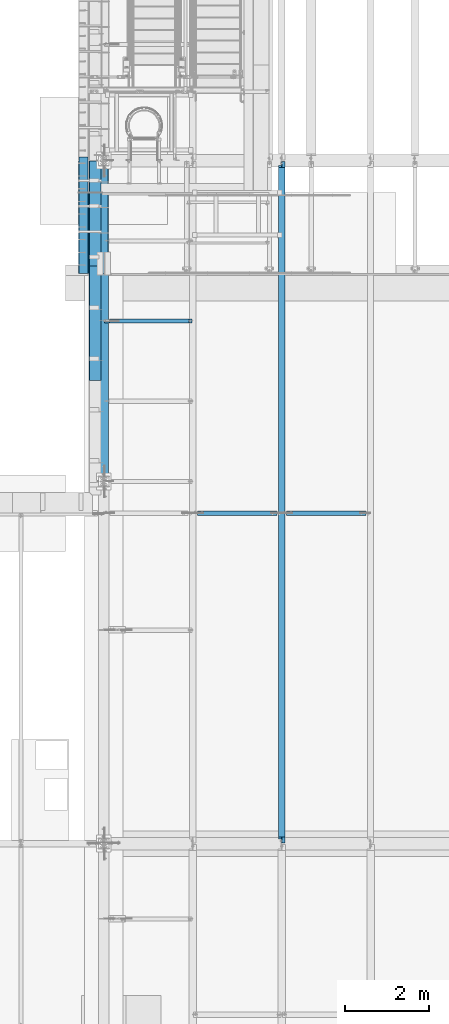
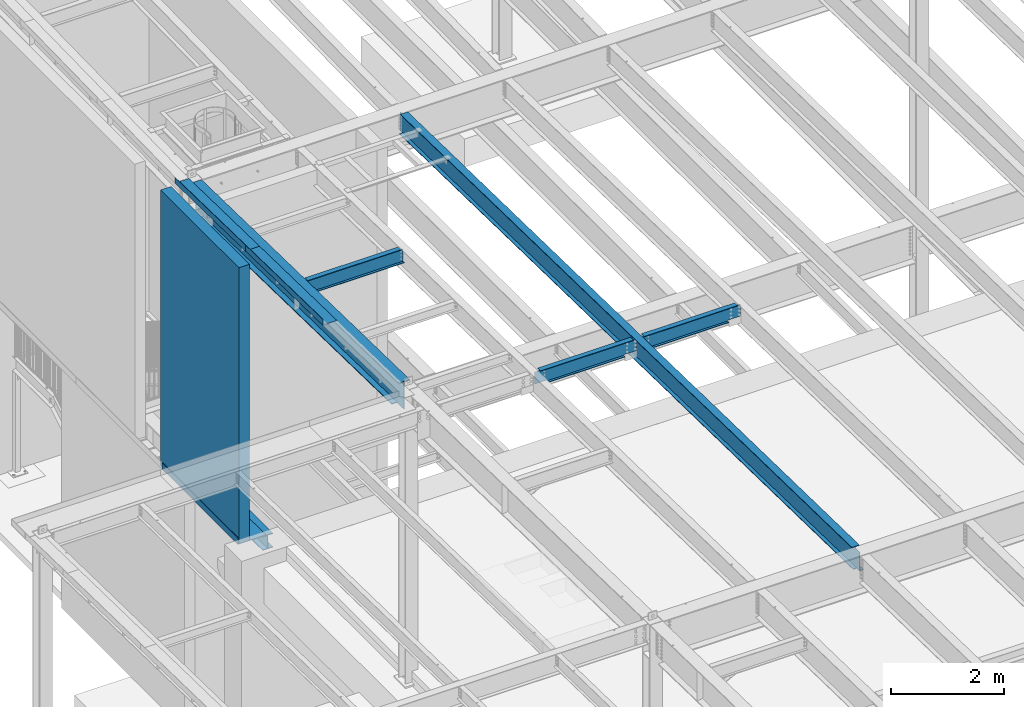
# One storey, part 1072 of 1763: 10 beams, 7 elements without a shape of their own.
"""IFC2X3 building model written with IfcOpenShell, lengths in millimetres."""

from ifc_helpers import new_model, si_unit, frame, origin_with_axes, place, context, subcontext, project, spatial, faceted_brep, material, type_object, element, aggregate, save


model = new_model("IFC2X3")

# Units and contexts
model_context = context("Model", 3, precision=1e-05, world=origin_with_axes())
body_context = subcontext(model_context, "Body", "Model", "MODEL_VIEW")
ifc_project = project(units=[si_unit("LENGTHUNIT", "METRE", prefix="MILLI"), si_unit("AREAUNIT", "SQUARE_METRE"), si_unit("VOLUMEUNIT", "CUBIC_METRE"), si_unit("MASSUNIT", "GRAM", prefix="KILO"), si_unit("TIMEUNIT", "SECOND"), si_unit("PLANEANGLEUNIT", "RADIAN"), si_unit("SOLIDANGLEUNIT", "STERADIAN"), si_unit("THERMODYNAMICTEMPERATUREUNIT", "DEGREE_CELSIUS"), si_unit("LUMINOUSINTENSITYUNIT", "LUMEN")], contexts=[model_context])

# Site, building, storey
site_placement = place(None, origin_with_axes())
site = spatial("IfcSite", under=ifc_project, at=site_placement, CompositionType="ELEMENT")
building_placement = place(site_placement, origin_with_axes())
building = spatial("IfcBuilding", under=site, at=building_placement, Name="Undefined", CompositionType="ELEMENT")
storey_placement = place(building_placement, origin_with_axes())
storey = spatial("IfcBuildingStorey", under=building, at=storey_placement, Name="Undefined", CompositionType="ELEMENT", Elevation=0.0)

# Assembly, beam
assembly_1_placement = place(storey_placement, origin_with_axes())
assembly_1 = element("IfcElementAssembly", 1, at=assembly_1_placement, inside=storey, Name="WALL", AssemblyPlace="NOTDEFINED", PredefinedType="REINFORCEMENT_UNIT")
ifc_material_1 = material(Name="CONCRETE/5000")
beam_type_1 = type_object("IfcBeamType", PredefinedType="NOTDEFINED")
beam_1_placement = place(assembly_1_placement, frame((-87858.0372736983, 27330.4000061035, 8189.9125), z_axis=(-1.0, 0.0, 0.0), x_axis=(0.0, 1.0, 0.0)))
beam_1 = element("IfcBeam", 2, at=beam_1_placement, type_object=beam_type_1, material=ifc_material_1, Name="WALL", context=body_context, shape_type="Brep", body=[
    faceted_brep([(0.0, 2986.0875, -107.949999999997), (0.0, 2986.0875, 107.949999999997), (2778.1249938965, 2986.0875, 107.949999999997), (2778.1249938965, 2986.0875, -107.949999999997), (0.0, -2986.0875, 107.949999999997), (2778.1249938965, -2986.0875, 107.949999999997), (0.0, -2986.0875, -107.949999999997), (2778.1249938965, -2986.0875, -107.949999999997)], [[[0, 1, 2, 3]], [[1, 4, 5, 2]], [[4, 6, 7, 5]], [[6, 0, 3, 7]], [[5, 7, 3, 2]], [[6, 4, 1, 0]]]),
])
aggregate(assembly_1, [beam_1])

assembly_2_placement = place(storey_placement, origin_with_axes())
assembly_2 = element("IfcElementAssembly", 3, at=assembly_2_placement, inside=storey, Name="BEAM", AssemblyPlace="NOTDEFINED", PredefinedType="RIGID_FRAME")
ifc_material_2 = material(Name="STEEL/A36")
beam_type_2 = type_object("IfcBeamType", PredefinedType="NOTDEFINED")
beam_2_placement = place(assembly_2_placement, frame((-87413.5372736984, 28675.0125, 5199.0625), z_axis=(0.0, -1.0, 0.0), x_axis=(-1.0, 0.0, 0.0)))
beam_2 = element("IfcBeam", 4, at=beam_2_placement, type_object=beam_type_2, material=ifc_material_2, Name="BENT_PLATE", context=body_context, shape_type="Brep", body=[
    faceted_brep([(349.250003051988, -4.76249999999982, -776.287548828121), (349.250003051988, 4.76249999999982, -776.287548828121), (349.250000000233, 4.76249999999982, -1344.6125), (349.250000000233, -4.76249999999982, -1344.6125), (0.0, -4.76249999999982, -776.287548828121), (0.0, 4.76249999999982, -776.287548828121), (571.5, 4.76249999999982, 1344.6125), (0.0, 4.76249999999982, 1344.6125), (0.0, -4.76249999999982, 1344.6125), (561.975000000006, -4.76249999999982, 1344.6125), (561.975000000006, -134.937496948242, 1344.6125), (571.5, -134.937496948242, 1344.6125), (571.5, 4.76249999999982, -1344.6125), (571.5, -134.937496948242, -1344.6125), (561.975000000006, -134.937496948242, -1344.6125), (561.975000000006, -4.76249999999982, -1344.6125)], [[[0, 1, 2, 3]], [[4, 5, 1, 0]], [[6, 7, 8, 9, 10, 11]], [[12, 6, 11, 13]], [[10, 14, 13, 11]], [[9, 15, 14, 10]], [[12, 13, 14, 15, 3, 2]], [[7, 6, 12, 2, 1, 5]], [[8, 7, 5, 4]], [[15, 9, 8, 4, 0, 3]]]),
])

# Assembly, beams
assembly_3_placement = place(storey_placement, origin_with_axes())
assembly_3 = element("IfcElementAssembly", 5, at=assembly_3_placement, inside=storey, Name="BEAM", AssemblyPlace="NOTDEFINED", PredefinedType="RIGID_FRAME")
beam_type_3 = type_object("IfcBeamType", PredefinedType="NOTDEFINED")
beam_3_placement = place(assembly_3_placement, frame((-87438.9372736983, 28764.1962141593, 11319.7790149965), z_axis=(0.0, -0.999781691287208, 0.0208942520059919), x_axis=(-1.0, 0.0, 0.0)))
beam_3 = element("IfcBeam", 6, at=beam_3_placement, type_object=beam_type_3, material=ifc_material_2, Name="BENT_PLATE", context=body_context, shape_type="Brep", body=[
    faceted_brep([(-5.0931703299284e-10, -3.17500000032851, -1254.12450000018), (7.13043846189976e-10, -3.17499999967549, 1254.12450000017), (5.0931703299284e-10, 3.17500000032305, 1254.12450000018), (-7.13043846189976e-10, 3.17499999967367, -1254.12450000018), (285.74999999514, 3.17500000944892, 1254.12450000004), (285.749999991167, 3.17500000879954, -1254.12450000031), (279.399999991176, -3.17499999140637, -1254.12450000032), (279.399999995148, -3.17499999075517, 1254.12450000003), (285.749999993728, -123.824999977416, 1254.1244999997), (285.749999992593, -123.824999975288, -1254.12450000065), (279.399999993722, -123.824999977416, 1254.12449999971), (279.399999992587, -123.824999975288, -1254.12450000064)], [[[0, 1, 2, 3]], [[3, 2, 4, 5]], [[1, 0, 6, 7]], [[5, 4, 8, 9]], [[4, 2, 1, 7, 10, 8]], [[7, 6, 11, 10]], [[6, 0, 3, 5, 9, 11]], [[10, 11, 9, 8]]]),
])
beam_4_placement = place(assembly_3_placement, frame((-87438.9372736983, 26139.0449326945, 11374.6415643874), z_axis=(0.0, -0.999781691287208, 0.0208942520059919), x_axis=(-1.0, 0.0, 0.0)))
beam_4 = element("IfcBeam", 7, at=beam_4_placement, type_object=beam_type_3, material=ifc_material_2, Name="BENT_PLATE", context=body_context, shape_type="Brep", body=[
    faceted_brep([(2.91038304567337e-11, -3.17499999963729, -1371.60000000396), (-2.91038304567337e-11, -3.17500000036489, 1371.60000000395), (-2.91038304567337e-11, 3.17499999963184, 1371.60000000395), (2.91038304567337e-11, 3.17500000035943, -1371.60000000396), (285.75000000016, 3.17499999930078, 1371.59999999897), (285.750000000276, 3.17499999982283, -1371.59999999897), (279.400000000271, -3.1750000001648, -1371.59999999897), (279.400000000154, -3.17500000068321, 1371.59999999897), (285.750000000218, -123.824997298658, 1371.59999999895), (285.750000000218, -123.824997298212, -1371.59999999898), (279.400000000212, -123.824997298658, 1371.59999999895), (279.400000000212, -123.824997298212, -1371.59999999898)], [[[0, 1, 2, 3]], [[3, 2, 4, 5]], [[1, 0, 6, 7]], [[5, 4, 8, 9]], [[4, 2, 1, 7, 10, 8]], [[7, 6, 11, 10]], [[6, 0, 3, 5, 9, 11]], [[10, 11, 9, 8]]]),
])

# Assembly, beam
assembly_4_placement = place(storey_placement, origin_with_axes())
assembly_4 = element("IfcElementAssembly", 8, at=assembly_4_placement, inside=storey, Name="BEAM", AssemblyPlace="NOTDEFINED", PredefinedType="RIGID_FRAME")
ifc_material_3 = material(Name="STEEL/A992")
beam_type_4 = type_object("IfcBeamType", Name="W18X40", PredefinedType="NOTDEFINED")
beam_5_placement = place(assembly_4_placement, frame((-83122.7515594126, 13685.8551306872, 11404.7768219843), z_axis=(0.0, 0.0209013539966291, 0.999781542838788), x_axis=(0.0, 0.999781542776098, -0.0209013569953182)))
beam_5 = element("IfcBeam", 9, at=beam_5_placement, type_object=beam_type_4, material=ifc_material_3, Name="BEAM", ObjectType="W18X40", context=body_context, shape_type="Brep", body=[
    faceted_brep([(126.194002738479, 4.26866853985121, -214.312499999893), (126.194002738466, 4.2688283926982, -227.01249999989), (29.339897632873, 4.26882972748717, -227.01250000019), (29.0743924101943, 4.26863241521642, -214.31250000018), (126.193992739341, 76.1999999999971, -214.312499999894), (126.193992739347, 76.1999999999971, -227.01249999989), (164.293992016979, -3.96875, 195.002501487832), (164.293992016979, 3.96875, 195.002501487832), (163.327262094397, 3.96875, 190.142421969791), (163.327262094397, -3.96875, 190.142421969791), (160.574248193921, 3.96875, 186.022245501637), (160.574248193921, -3.96875, 186.022245501637), (156.454071725771, 3.96875, 183.269231601158), (156.454071725771, -3.96875, 183.269231601158), (151.593992207727, 3.96875, 182.302501678567), (151.593992207727, -3.96875, 182.302501678567), (20.7827897637508, 3.96875, 182.30250167849), (20.7827897637508, -3.96875, 182.30250167849), (29.0743924101943, -3.96875, -214.31250000018), (16325.1468877506, -3.96875, -214.312499990354), (16317.1207899894, -3.96875, 169.60249800784), (16187.3164864569, -3.96875, 169.602498007764), (16182.4564069388, -3.96875, 170.569227930349), (16178.3362304707, -3.96875, 173.322241830821), (16175.5832165702, -3.96875, 177.442418298971), (16174.6164866476, -3.96875, 182.302497817014), (16174.6164868948, -3.96875, 214.312500009495), (164.29399201697, -3.96875, 214.312500000067), (29.0743924101943, -76.1999999999971, -214.31250000018), (16325.1468877506, -76.1999999999971, -214.312499990354), (29.339897632873, -76.1999999999971, -227.01250000019), (16325.412392986, -76.1999999999971, -227.012499990351), (16225.1450550741, 76.1999999999971, -215.844156205017), (16225.1450550741, 4.71875000001455, -215.844156205017), (16225.4164836211, 4.71875000001455, -215.838481740431), (16225.4164771875, 76.1999999999971, -215.838481874931), (16225.1130343856, 4.71875000001455, -214.312499990412), (16225.1130343856, 76.1999999999971, -214.312499990412), (16225.4164836211, 4.71875000001455, -214.312499990414), (16225.4164838328, 4.26882845565706, -214.312499990412), (16225.4164838328, 4.26866860519658, -227.012499990411), (16225.4164773588, 76.1999999999971, -227.012499990409), (16325.412392986, 4.2686776052069, -227.012499990351), (16325.1468877506, 4.26883743175858, -214.312499990354), (16325.1468877506, 3.96875, -214.312499990354), (16317.1207899894, 3.96875, 169.60249800784), (16187.3164864569, 3.96875, 169.602498007764), (16182.4564069388, 3.96875, 170.569227930349), (16178.3362304707, 3.96875, 173.322241830821), (16175.5832165702, 3.96875, 177.442418298971), (16174.6164866476, 3.96875, 182.302497817014), (16174.6164868948, -76.1999999999971, 227.01250000949), (16174.6164868948, -76.1999999999971, 214.312500009495), (16174.6164868948, 3.96875, 214.312500009495), (16174.6164868948, 76.1999999999971, 214.312500009495), (16174.6164868948, 76.1999999999971, 227.01250000949), (164.29399201697, 3.96875, 214.312500000067), (164.29399201697, 76.1999999999971, 214.312500000067), (164.293992016963, 76.1999999999971, 227.012500000064), (164.293992016963, -76.1999999999971, 227.012500000064), (164.29399201697, -76.1999999999971, 214.312500000067), (29.0743924101943, 3.96875, -214.31250000018)], [[[0, 1, 2, 3]], [[4, 5, 1, 0]], [[6, 7, 8, 9]], [[9, 8, 10, 11]], [[11, 10, 12, 13]], [[13, 12, 14, 15]], [[15, 14, 16, 17]], [[9, 11, 13, 15, 17, 18, 19, 20, 21, 22, 23, 24, 25, 26, 27, 6]], [[18, 28, 29, 19]], [[28, 30, 31, 29]], [[32, 33, 34, 35]], [[36, 33, 32, 37]], [[33, 36, 38, 34]], [[39, 40, 41, 35, 34, 38]], [[42, 40, 39, 43]], [[44, 45, 20, 19, 29, 31, 42, 43]], [[20, 45, 46, 21]], [[21, 46, 47, 22]], [[22, 47, 48, 23]], [[23, 48, 49, 24]], [[24, 49, 50, 25]], [[51, 52, 26, 25, 50, 53, 54, 55]], [[54, 53, 56, 57]], [[55, 54, 57, 58]], [[51, 55, 58, 59]], [[52, 51, 59, 60]], [[26, 52, 60, 27]], [[59, 58, 57, 56, 7, 6, 27, 60]], [[53, 50, 49, 48, 47, 46, 45, 44, 61, 16, 14, 12, 10, 8, 7, 56]], [[30, 28, 18, 17, 16, 61, 3, 2]], [[41, 40, 42, 31, 30, 2, 1, 5]], [[37, 32, 35, 41, 5, 4]], [[61, 44, 43, 39, 38, 36, 37, 4, 0, 3]]]),
])
aggregate(assembly_4, [beam_5])

assembly_5_placement = place(storey_placement, origin_with_axes())
assembly_5 = element("IfcElementAssembly", 10, at=assembly_5_placement, inside=storey, Name="BEAM", AssemblyPlace="NOTDEFINED", PredefinedType="RIGID_FRAME")
beam_type_5 = type_object("IfcBeamType", Name="W12X22", PredefinedType="NOTDEFINED")
beam_6_placement = place(assembly_5_placement, frame((-87375.4372736983, 26187.4000001637, 11214.8803075204), z_axis=(0.0, 0.0, 1.0), x_axis=(1.0, 0.0, 0.0)))
beam_6 = element("IfcBeam", 11, at=beam_6_placement, type_object=beam_type_5, material=ifc_material_3, Name="BEAM", ObjectType="W12X22", context=body_context, shape_type="Brep", body=[
    faceted_brep([(18.2562499999913, -3.17499999999927, -144.4625), (18.2562499999913, -50.7999999999993, -144.4625), (2109.67410714286, -50.7999999999993, -144.4625), (2109.67410714286, -3.17499999999927, -144.4625), (18.2562499999913, -50.7999999999993, -155.575000000001), (2109.67410714286, -50.7999999999993, -155.575000000001), (2109.67410714286, 3.17499999999927, -144.4625), (2109.67410714286, 50.7999999999993, -144.4625), (132.556249999994, 50.7999999999993, -144.4625), (132.556249999994, 3.17575008238782, -144.4625), (2033.47410714286, -50.7999999999993, 155.575000000001), (2033.47410714286, -50.7999999999993, 144.4625), (2033.47410714286, -3.17499999999927, 144.4625), (2033.47410714286, -3.17499999999927, 136.265001487105), (2033.47410714286, 3.17499999999927, 136.265001487105), (2033.47410714286, 3.17499999999927, 144.4625), (2033.47410714286, 50.7999999999993, 144.4625), (2033.47410714286, 50.7999999999993, 155.575000000001), (2034.44083706544, -3.17499999999927, 131.404921969059), (2034.44083706544, 3.17499999999927, 131.404921969059), (2037.19385096592, -3.17499999999927, 127.284745500905), (2037.19385096592, 3.17499999999927, 127.284745500905), (2041.31402743408, -3.17499999999927, 124.531731600428), (2041.31402743408, 3.17499999999927, 124.531731600428), (2046.17410695212, -3.17499999999927, 123.56500167784), (2046.17410695212, 3.17499999999927, 123.56500167784), (2109.67410714286, -3.17499999999927, 123.56500167784), (2109.67410714286, 3.17499999999927, 123.56500167784), (2109.67410714286, 50.7999999999993, -155.575000000001), (132.556249999994, 50.7999999999993, -155.575000000001), (132.556249999994, 3.17575008238782, -155.575000000001), (18.2562499999913, 3.17575008238782, -155.575000000001), (18.2562499999913, 3.17499999999927, -144.4625), (124.716329708754, -3.17499999999927, 105.741729925645), (124.716329708754, 3.17500736736474, 105.741729925645), (119.856250190714, 3.1750086254724, 104.775000003057), (119.856250190714, -3.17499999999927, 104.775000003057), (128.836506176915, -3.17499999999927, 108.494743826122), (128.836506176915, 3.17500378457771, 108.494743826122), (131.589520077396, -3.17499999999927, 112.614920294276), (131.589520077396, 3.17499842256075, 112.614920294276), (132.55624999998, -3.17499999999927, 117.474999812322), (132.55624999998, 3.17499209762536, 117.474999812322), (18.2562499999913, 3.17499999999927, -137.353076309833), (18.2562499999913, 3.17499999999927, 104.775000003057), (132.55624999998, 3.17499999999927, 144.4625), (132.55624999998, 50.7999999999993, 144.4625), (132.55624999998, 50.7999999999993, 155.575000000001), (132.55624999998, -50.7999999999993, 155.575000000001), (132.55624999998, -50.7999999999993, 144.4625), (132.55624999998, -3.17499999999927, 144.4625), (18.2562499999913, -3.17499999999927, 104.775000003057)], [[[0, 1, 2, 3]], [[1, 4, 5, 2]], [[6, 7, 8, 9]], [[10, 11, 12, 13, 14, 15, 16, 17]], [[18, 19, 14, 13]], [[20, 21, 19, 18]], [[22, 23, 21, 20]], [[24, 25, 23, 22]], [[26, 27, 25, 24]], [[3, 2, 5, 28, 7, 6, 27, 26]], [[7, 28, 29, 8]], [[8, 29, 30, 9]], [[28, 5, 4, 31, 30, 29]], [[9, 30, 31, 32]], [[33, 34, 35, 36]], [[37, 38, 34, 33]], [[39, 40, 38, 37]], [[41, 42, 40, 39]], [[15, 14, 19, 21, 23, 25, 27, 6, 9, 32, 43, 44, 35, 34, 38, 40, 42, 45]], [[16, 15, 45, 46]], [[17, 16, 46, 47]], [[10, 17, 47, 48]], [[11, 10, 48, 49]], [[12, 11, 49, 50]], [[48, 47, 46, 45, 42, 41, 50, 49]], [[39, 37, 33, 36, 51, 0, 3, 26, 24, 22, 20, 18, 13, 12, 50, 41]], [[43, 32, 31, 4, 1, 0, 51, 44]], [[36, 35, 44, 51]]]),
])
aggregate(assembly_5, [beam_6])

assembly_6_placement = place(storey_placement, origin_with_axes())
assembly_6 = element("IfcElementAssembly", 12, at=assembly_6_placement, inside=storey, Name="BEAM", AssemblyPlace="NOTDEFINED", PredefinedType="RIGID_FRAME")
beam_7_placement = place(assembly_6_placement, frame((-83122.7515594126, 21589.9999999839, 11311.0204686664), z_axis=(0.0, 0.0, 1.0), x_axis=(1.0, 0.0, 0.0)))
beam_7 = element("IfcBeam", 13, at=beam_7_placement, type_object=beam_type_5, material=ifc_material_3, Name="BEAM", ObjectType="W12X22", context=body_context, shape_type="Brep", body=[
    faceted_brep([(1842.97410714286, -3.17499999999927, -144.4625), (1842.97410714286, -50.7999999999993, -144.4625), (1842.97410714286, -50.7999999999993, -155.575000000001), (1842.97410714286, 50.7999999999993, -155.575000000001), (1842.97410714286, 50.7999999999993, -144.4625), (1842.97410714286, 3.1750000136708, -144.4625), (1842.97410714286, 3.17500003513851, -142.874999804897), (1842.97410714286, -3.17499999999927, -142.874999804897), (1843.94083706544, 3.17500003439636, -138.014920286851), (1843.94083706544, -3.17499999999927, -138.014920286851), (1846.69385096592, 3.17500003376699, -133.894743818697), (1846.69385096592, -3.17499999999927, -133.894743818697), (1850.81402743408, 3.17500003334135, -131.141729918219), (1850.81402743408, -3.17499999999927, -131.141729918219), (1855.67410695212, 3.17500003318855, -130.174999995632), (1855.67410695212, -3.17499999999927, -130.174999995632), (2109.67410714286, -3.17499999999927, -130.174999995632), (2109.67410714286, 3.17499999999927, -130.174999995632), (111.918749999997, 3.17499999999927, 144.4625), (111.918749999997, 50.7999999999993, 144.4625), (2014.42410714286, 50.7999999999993, 144.4625), (2014.42410714286, 3.17499999999927, 144.4625), (283.368749999994, -3.17499999999927, -142.874999804897), (283.368749999994, 3.17500003893292, -142.874999804897), (283.368749999994, 3.17500009360811, -144.4625), (283.368749999994, 50.7999999999993, -144.4625), (283.368749999994, 50.7999999999993, -155.575000000001), (283.368749999994, -50.7999999999993, -155.575000000001), (283.368749999994, -50.7999999999993, -144.4625), (283.368749999994, -3.17499999999927, -144.4625), (282.40202007741, -3.17499999999927, -138.014920286851), (282.40202007741, 3.1750000381362, -138.014920286851), (279.649006176929, -3.17499999999927, -133.894743818697), (279.649006176929, 3.17500003745954, -133.894743818697), (275.528829708768, -3.17499999999927, -131.141729918219), (275.528829708768, 3.17500003700843, -131.141729918219), (270.668750190729, -3.17499999999927, -130.174999995632), (270.668750190729, 3.17500003684836, -130.174999995632), (16.6687500000116, -3.17499999999927, -130.174999995632), (16.6687500000116, 3.17499999999927, -130.174999995632), (16.6687500000116, -3.17499999999927, 130.175000004368), (16.6687500000116, 3.17499999999927, 130.175000004368), (99.218750190732, -3.17499999999927, 130.175000004368), (99.218750190732, 3.1749999944368, 130.175000004368), (104.078829708771, -3.17499999999927, 131.141729926956), (104.078829708771, 3.17499999427673, 131.141729926956), (108.199006176932, -3.17499999999927, 133.894743827434), (108.199006176932, 3.17499999382926, 133.894743827434), (110.952020077413, -3.17499999999927, 138.014920295587), (110.952020077413, 3.17499999315623, 138.014920295587), (111.918749999997, -3.17499999999927, 142.874999813634), (111.918749999997, 3.17499999236315, 142.874999813634), (111.918749999997, -50.7999999999993, 155.575000000001), (111.918749999997, 50.7999999999993, 155.575000000001), (111.918749999997, -3.17499999999927, 144.4625), (111.918749999997, -50.7999999999993, 144.4625), (2014.42410714286, -3.17499999999927, 144.4625), (2014.42410714286, -50.7999999999993, 144.4625), (2014.42410714286, -50.7999999999993, 155.575000000001), (2014.42410714286, 50.7999999999993, 155.575000000001), (2014.42410714286, -3.17499999999927, 142.874999813634), (2014.42410714286, 3.17499999175197, 142.874999813634), (2015.39083706544, -3.17499999999927, 138.014920295587), (2015.39083706544, 3.17499999248685, 138.014920295587), (2018.14385096592, -3.17499999999927, 133.894743827434), (2018.14385096592, 3.17499999310894, 133.894743827434), (2022.26402743408, -3.17499999999927, 131.141729926956), (2022.26402743408, 3.17499999352367, 131.141729926956), (2027.12410695212, -3.17499999999927, 130.175000004368), (2027.12410695212, 3.17499999366555, 130.175000004368), (2109.67410714286, -3.17499999999927, 130.175000004368), (2109.67410714286, 3.17499999999927, 130.175000004368)], [[[0, 1, 2, 3, 4, 5, 6, 7]], [[7, 6, 8, 9]], [[9, 8, 10, 11]], [[11, 10, 12, 13]], [[13, 12, 14, 15]], [[16, 15, 14, 17]], [[18, 19, 20, 21]], [[22, 23, 24, 25, 26, 27, 28, 29]], [[30, 31, 23, 22]], [[32, 33, 31, 30]], [[34, 35, 33, 32]], [[36, 37, 35, 34]], [[38, 39, 37, 36]], [[40, 41, 39, 38]], [[42, 43, 41, 40]], [[44, 45, 43, 42]], [[46, 47, 45, 44]], [[48, 49, 47, 46]], [[50, 51, 49, 48]], [[52, 53, 19, 18, 51, 50, 54, 55]], [[55, 54, 56, 57]], [[52, 55, 57, 58]], [[53, 52, 58, 59]], [[19, 53, 59, 20]], [[58, 57, 56, 60, 61, 21, 20, 59]], [[62, 63, 61, 60]], [[64, 65, 63, 62]], [[66, 67, 65, 64]], [[68, 69, 67, 66]], [[70, 71, 69, 68]], [[71, 70, 16, 17]], [[12, 10, 8, 6, 5, 24, 23, 31, 33, 35, 37, 39, 41, 43, 45, 47, 49, 51, 18, 21, 61, 63, 65, 67, 69, 71, 17, 14]], [[25, 24, 5, 4]], [[26, 25, 4, 3]], [[27, 26, 3, 2]], [[28, 27, 2, 1]], [[29, 28, 1, 0]], [[70, 68, 66, 64, 62, 60, 56, 54, 50, 48, 46, 44, 42, 40, 38, 36, 34, 32, 30, 22, 29, 0, 7, 9, 11, 13, 15, 16]]]),
])
aggregate(assembly_6, [beam_7])

assembly_7_placement = place(storey_placement, origin_with_axes())
assembly_7 = element("IfcElementAssembly", 14, at=assembly_7_placement, inside=storey, Name="BEAM", AssemblyPlace="NOTDEFINED", PredefinedType="RIGID_FRAME")
beam_8_placement = place(assembly_7_placement, frame((-85249.0944165555, 21589.9999999839, 11311.0204686664), z_axis=(0.0, 0.0, 1.0), x_axis=(1.0, 0.0, 0.0)))
beam_8 = element("IfcBeam", 15, at=beam_8_placement, type_object=beam_type_5, material=ifc_material_3, Name="BEAM", ObjectType="W12X22", context=body_context, shape_type="Brep", body=[
    faceted_brep([(1842.97410714286, -3.17499999999927, -144.4625), (1842.97410714286, -50.7999999999993, -144.4625), (1842.97410714286, -50.7999999999993, -155.575000000001), (1842.97410714286, 50.7999999999993, -155.575000000001), (1842.97410714286, 50.7999999999993, -144.4625), (1842.97410714286, 3.1750000136708, -144.4625), (1842.97410714286, 3.17500003513851, -142.874999804897), (1842.97410714286, -3.17499999999927, -142.874999804897), (1843.94083706544, 3.17500003439636, -138.014920286851), (1843.94083706544, -3.17499999999927, -138.014920286851), (1846.69385096592, 3.17500003376699, -133.894743818697), (1846.69385096592, -3.17499999999927, -133.894743818697), (1850.81402743408, 3.17500003334135, -131.141729918219), (1850.81402743408, -3.17499999999927, -131.141729918219), (1855.67410695212, 3.17500003318855, -130.174999995632), (1855.67410695212, -3.17499999999927, -130.174999995632), (2109.67410714286, -3.17499999999927, -130.174999995632), (2109.67410714286, 3.17499999999927, -130.174999995632), (111.918749999997, 3.17499999999927, 144.4625), (111.918749999997, 50.7999999999993, 144.4625), (2014.42410714286, 50.7999999999993, 144.4625), (2014.42410714286, 3.17499999999927, 144.4625), (283.368749999994, -3.17499999999927, -142.874999804897), (283.368749999994, 3.17500003893292, -142.874999804897), (283.368749999994, 3.17500009360811, -144.4625), (283.368749999994, 50.7999999999993, -144.4625), (283.368749999994, 50.7999999999993, -155.575000000001), (283.368749999994, -50.7999999999993, -155.575000000001), (283.368749999994, -50.7999999999993, -144.4625), (283.368749999994, -3.17499999999927, -144.4625), (282.40202007741, -3.17499999999927, -138.014920286851), (282.40202007741, 3.1750000381362, -138.014920286851), (279.649006176929, -3.17499999999927, -133.894743818697), (279.649006176929, 3.17500003745954, -133.894743818697), (275.528829708768, -3.17499999999927, -131.141729918219), (275.528829708768, 3.17500003700843, -131.141729918219), (270.668750190729, -3.17499999999927, -130.174999995632), (270.668750190729, 3.17500003684836, -130.174999995632), (16.6687500000116, -3.17499999999927, -130.174999995632), (16.6687500000116, 3.17499999999927, -130.174999995632), (16.6687500000116, -3.17499999999927, 130.175000004368), (16.6687500000116, 3.17499999999927, 130.175000004368), (99.218750190732, -3.17499999999927, 130.175000004368), (99.218750190732, 3.1749999944368, 130.175000004368), (104.078829708771, -3.17499999999927, 131.141729926956), (104.078829708771, 3.17499999427673, 131.141729926956), (108.199006176932, -3.17499999999927, 133.894743827434), (108.199006176932, 3.17499999382926, 133.894743827434), (110.952020077413, -3.17499999999927, 138.014920295587), (110.952020077413, 3.17499999315623, 138.014920295587), (111.918749999997, -3.17499999999927, 142.874999813634), (111.918749999997, 3.17499999236315, 142.874999813634), (111.918749999997, -50.7999999999993, 155.575000000001), (111.918749999997, 50.7999999999993, 155.575000000001), (111.918749999997, -3.17499999999927, 144.4625), (111.918749999997, -50.7999999999993, 144.4625), (2014.42410714286, -3.17499999999927, 144.4625), (2014.42410714286, -50.7999999999993, 144.4625), (2014.42410714286, -50.7999999999993, 155.575000000001), (2014.42410714286, 50.7999999999993, 155.575000000001), (2014.42410714286, -3.17499999999927, 142.874999813634), (2014.42410714286, 3.17499999175197, 142.874999813634), (2015.39083706544, -3.17499999999927, 138.014920295587), (2015.39083706544, 3.17499999248685, 138.014920295587), (2018.14385096592, -3.17499999999927, 133.894743827434), (2018.14385096592, 3.17499999310894, 133.894743827434), (2022.26402743408, -3.17499999999927, 131.141729926956), (2022.26402743408, 3.17499999352367, 131.141729926956), (2027.12410695212, -3.17499999999927, 130.175000004368), (2027.12410695212, 3.17499999366555, 130.175000004368), (2109.67410714286, -3.17499999999927, 130.175000004368), (2109.67410714286, 3.17499999999927, 130.175000004368)], [[[0, 1, 2, 3, 4, 5, 6, 7]], [[7, 6, 8, 9]], [[9, 8, 10, 11]], [[11, 10, 12, 13]], [[13, 12, 14, 15]], [[16, 15, 14, 17]], [[18, 19, 20, 21]], [[22, 23, 24, 25, 26, 27, 28, 29]], [[30, 31, 23, 22]], [[32, 33, 31, 30]], [[34, 35, 33, 32]], [[36, 37, 35, 34]], [[38, 39, 37, 36]], [[40, 41, 39, 38]], [[42, 43, 41, 40]], [[44, 45, 43, 42]], [[46, 47, 45, 44]], [[48, 49, 47, 46]], [[50, 51, 49, 48]], [[52, 53, 19, 18, 51, 50, 54, 55]], [[55, 54, 56, 57]], [[52, 55, 57, 58]], [[53, 52, 58, 59]], [[19, 53, 59, 20]], [[58, 57, 56, 60, 61, 21, 20, 59]], [[62, 63, 61, 60]], [[64, 65, 63, 62]], [[66, 67, 65, 64]], [[68, 69, 67, 66]], [[70, 71, 69, 68]], [[71, 70, 16, 17]], [[12, 10, 8, 6, 5, 24, 23, 31, 33, 35, 37, 39, 41, 43, 45, 47, 49, 51, 18, 21, 61, 63, 65, 67, 69, 71, 17, 14]], [[25, 24, 5, 4]], [[26, 25, 4, 3]], [[27, 26, 3, 2]], [[28, 27, 2, 1]], [[29, 28, 1, 0]], [[70, 68, 66, 64, 62, 60, 56, 54, 50, 48, 46, 44, 42, 40, 38, 36, 34, 32, 30, 22, 29, 0, 7, 9, 11, 13, 15, 16]]]),
])
aggregate(assembly_7, [beam_8])

# Beam
beam_type_6 = type_object("IfcBeamType", Name="W24X76", PredefinedType="NOTDEFINED")
beam_9_placement = place(assembly_3_placement, frame((-87375.4372736983, 22345.6646016967, 11147.4643141926), z_axis=(0.0, 0.0208942520060009, 0.999781691287208), x_axis=(0.0, 0.999781691287208, -0.0208942520059949)))
beam_9 = element("IfcBeam", 16, at=beam_9_placement, type_object=beam_type_6, material=ifc_material_3, Name="BEAM", ObjectType="W24X76", context=body_context, shape_type="Brep", body=[
    faceted_brep([(7280.31761762892, 5.85656133187877, -285.749999998165), (7280.31761762933, 5.85594161524205, -303.212499998168), (7280.31754139283, 114.300000000003, -303.212499998168), (7280.31754139282, 114.300000000003, -285.749999998163), (7540.65448726615, 5.85612463288999, -303.212499998101), (7540.28954171974, 5.8567440930201, -285.749999998096), (7540.28954171974, -5.55624999999418, -285.749999998096), (152.039122278573, -5.55624999999418, -285.750000000011), (152.039122278573, -5.85674569010735, -285.750000000011), (400.067379000891, -5.85656140337233, -285.749999999945), (400.067459575013, -114.300000000003, -285.749999999945), (7280.31770198941, -114.300000000003, -285.749999998165), (7280.31762575453, -5.85594161076006, -285.749999998165), (7540.28954171974, -5.85575885050639, -285.749999998096), (140.095449850425, -5.55624999999418, 285.750000000089), (7528.3458692916, -5.55624999999418, 285.750000002001), (140.095449850425, -114.300000000003, 285.750000000089), (7528.3458692916, -114.300000000003, 285.750000002001), (139.730504304011, -114.300000000003, 303.212500000091), (7527.98092374518, -114.300000000003, 303.212500002004), (139.730504304011, 114.300000000003, 303.212500000091), (7527.98092374518, 114.300000000003, 303.212500002004), (140.095449850425, 114.300000000003, 285.750000000089), (7528.3458692916, 114.300000000003, 285.750000002001), (140.095449850425, 5.55624999999418, 285.750000000089), (7528.3458692916, 5.55624999999418, 285.750000002001), (152.039122278573, 5.55624999999418, -285.750000000011), (7540.28954171974, 5.55624999999418, -285.749999998096), (400.067289779814, 114.300000000003, -285.749999999945), (400.067289779818, 114.300000000003, -303.212499999949), (400.067370352164, 5.85656132014992, -303.212499999949), (400.067370352645, 5.85594158954336, -285.749999999945), (152.404067824988, 5.85637730627786, -303.212500000014), (152.039122278573, 5.85575730443816, -285.750000000011), (152.404067824988, -5.85612568826764, -303.212500000014), (400.067379000411, -5.85594167276577, -303.212499999951), (400.067459575017, -114.300000000003, -303.212499999951), (7280.31770198942, -114.300000000003, -303.212499998166), (7280.31762575493, -5.85656132738222, -303.212499998166), (7540.65448726615, -5.8563783106365, -303.212499998101)], [[[0, 1, 2, 3]], [[4, 1, 0, 5]], [[6, 7, 8, 9, 10, 11, 12, 13]], [[14, 7, 6, 15]], [[16, 14, 15, 17]], [[18, 16, 17, 19]], [[20, 18, 19, 21]], [[22, 20, 21, 23]], [[24, 22, 23, 25]], [[26, 24, 25, 27]], [[28, 29, 30, 31]], [[31, 30, 32, 33]], [[7, 14, 16, 18, 20, 22, 24, 26, 33, 32, 34, 8]], [[8, 34, 35, 9]], [[10, 9, 35, 36]], [[10, 36, 37, 11]], [[11, 37, 38, 12]], [[39, 13, 12, 38]], [[27, 25, 23, 21, 19, 17, 15, 6, 13, 39, 4, 5]], [[3, 28, 31, 33, 26, 27, 5, 0]], [[29, 28, 3, 2]], [[39, 38, 37, 36, 35, 34, 32, 30, 29, 2, 1, 4]]]),
])

aggregate(assembly_3, [beam_3, beam_4, beam_9])

beam_type_7 = type_object("IfcBeamType", Name="W12X50", PredefinedType="NOTDEFINED")
beam_10_placement = place(assembly_2_placement, frame((-87375.4372736983, 27279.6, 5038.725), z_axis=(0.0, 0.0, 1.0), x_axis=(0.0, 1.0, 0.0)))
beam_10 = element("IfcBeam", 17, at=beam_10_placement, type_object=beam_type_7, material=ifc_material_3, Name="BEAM", ObjectType="W12X50", context=body_context, shape_type="Brep", body=[
    faceted_brep([(50.7999999999993, -103.1875, -139.7), (50.7999999999993, -103.1875, -155.575), (2598.7375, -103.1875, -155.575), (2598.7375, -103.1875, -139.7), (50.7999999999993, -4.76250000000073, -139.7), (2598.7375, -4.76249999999709, -139.7), (50.7999999999993, -4.76250000000073, 139.7), (2598.7375, -4.76249999999709, 139.7), (50.7999999999993, -103.1875, 139.7), (2598.7375, -103.1875, 139.7), (50.7999999999993, -103.1875, 155.575), (2598.7375, -103.1875, 155.575), (50.7999999999993, 103.1875, 155.575), (2598.7375, 103.1875, 155.575), (50.7999999999993, 103.1875, 139.7), (2598.7375, 103.1875, 139.7), (50.7999999999993, 4.76250000000073, 139.7), (2598.7375, 4.76249999999709, 139.7), (50.7999999999993, 4.76250000000073, -139.7), (2598.7375, 4.76249999999709, -139.7), (50.7999999999993, 103.1875, -139.7), (2598.7375, 103.1875, -139.7), (50.7999999999993, 103.1875, -155.575), (2598.7375, 103.1875, -155.575)], [[[0, 1, 2, 3]], [[4, 0, 3, 5]], [[6, 4, 5, 7]], [[8, 6, 7, 9]], [[10, 8, 9, 11]], [[12, 10, 11, 13]], [[14, 12, 13, 15]], [[16, 14, 15, 17]], [[18, 16, 17, 19]], [[20, 18, 19, 21]], [[1, 0, 4, 6, 8, 10, 12, 14, 16, 18, 20, 22]], [[1, 22, 23, 2]], [[19, 17, 15, 13, 11, 9, 7, 5, 3, 2, 23, 21]], [[22, 20, 21, 23]]]),
])

aggregate(assembly_2, [beam_2, beam_10])

save(model, "model.ifc")
